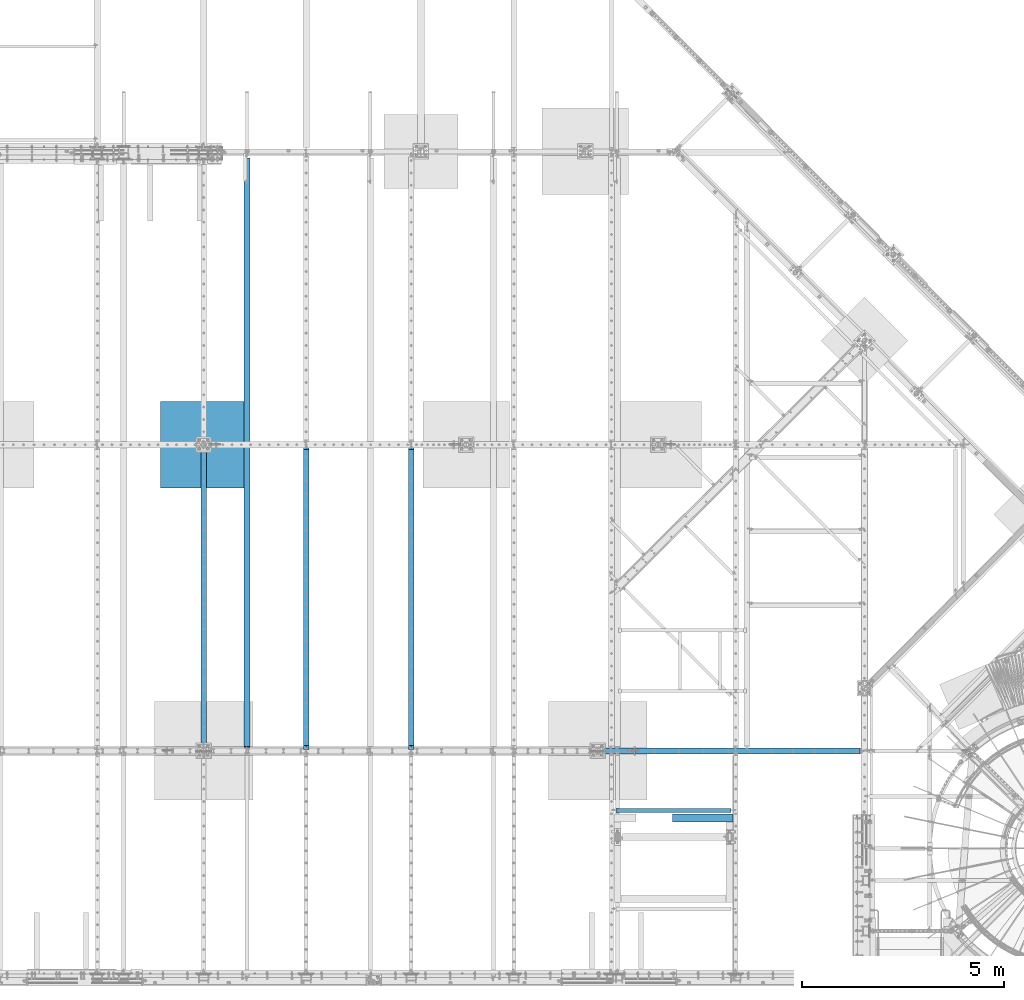
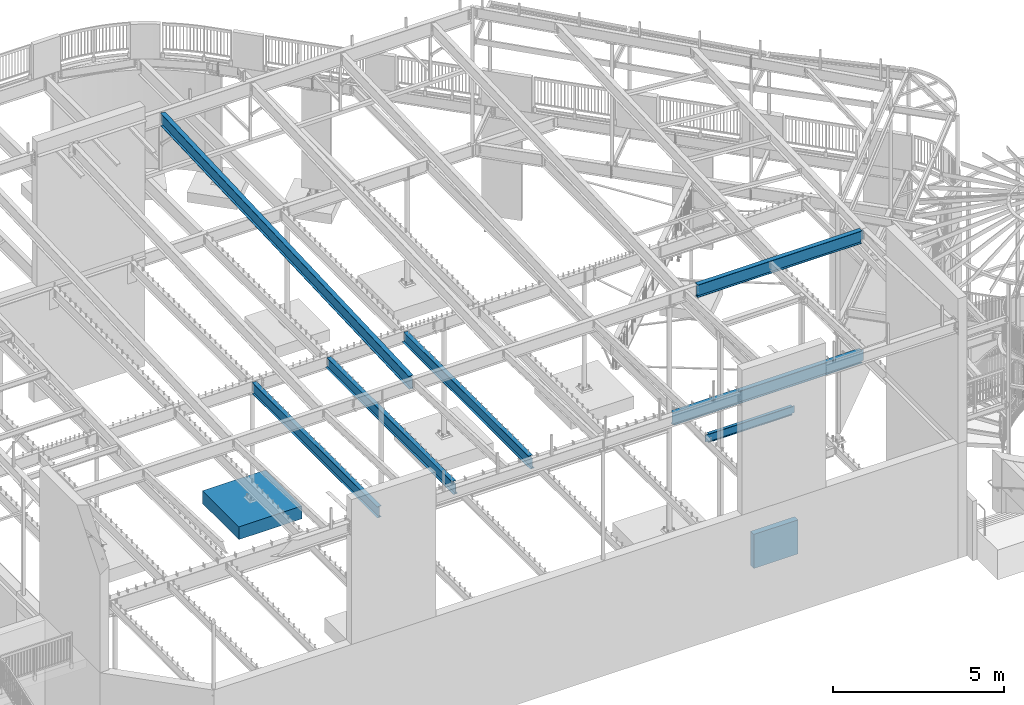
# One storey, part 316 of 975: 9 beams.
"""IFC2X3 building model written with IfcOpenShell, lengths in millimetres."""

from ifc_helpers import new_model, si_unit, frame, origin_with_axes, place, context, subcontext, project, spatial, faceted_brep, material, type_object, element, save


model = new_model("IFC2X3")

# Units and contexts
model_context = context("Model", 3, precision=1e-05, world=origin_with_axes())
body_context = subcontext(model_context, "Body", "Model", "MODEL_VIEW")
ifc_project = project(units=[si_unit("LENGTHUNIT", "METRE", prefix="MILLI"), si_unit("AREAUNIT", "SQUARE_METRE"), si_unit("VOLUMEUNIT", "CUBIC_METRE"), si_unit("MASSUNIT", "GRAM", prefix="KILO"), si_unit("TIMEUNIT", "SECOND"), si_unit("PLANEANGLEUNIT", "RADIAN"), si_unit("SOLIDANGLEUNIT", "STERADIAN"), si_unit("THERMODYNAMICTEMPERATUREUNIT", "DEGREE_CELSIUS"), si_unit("LUMINOUSINTENSITYUNIT", "LUMEN")], contexts=[model_context])

# Site, building, storey
site_placement = place(None, origin_with_axes())
site = spatial("IfcSite", under=ifc_project, at=site_placement, CompositionType="ELEMENT")
building_placement = place(site_placement, origin_with_axes())
building = spatial("IfcBuilding", under=site, at=building_placement, Name="Undefined", CompositionType="ELEMENT")
storey_placement = place(building_placement, origin_with_axes())
storey = spatial("IfcBuildingStorey", under=building, at=storey_placement, Name="Undefined", CompositionType="ELEMENT", Elevation=0.0)

# Beams
ifc_material_1 = material(Name="CONCRETE/5000")
beam_type_1 = type_object("IfcBeamType", PredefinedType="NOTDEFINED")
beam_1_placement = place(storey_placement, frame((25079.3251220703, 4160.83746255972, -609.6), z_axis=(0.0, 0.0, 1.0), x_axis=(1.0, 0.0, 0.0)))
element("IfcBeam", 1, at=beam_1_placement, inside=storey, type_object=beam_type_1, material=ifc_material_1, Name="WALL", context=body_context, shape_type="Brep", body=[
    faceted_brep([(0.0, 96.8375000000001, -609.6), (0.0, 96.8375000000001, 609.6), (1501.77487792969, 96.8374999999996, 609.6), (1501.77487792969, 96.8374999999996, -609.6), (0.0, -96.8375000000001, 609.6), (1501.77487792969, -96.8375000000001, 609.6), (0.0, -96.8375000000001, -609.6), (1501.77487792969, -96.8375000000001, -609.6)], [[[0, 1, 2, 3]], [[1, 4, 5, 2]], [[4, 6, 7, 5]], [[6, 0, 3, 7]], [[5, 7, 3, 2]], [[6, 4, 1, 0]]]),
])
ifc_material_2 = material(Name="STEEL/A992")
beam_type_2 = type_object("IfcBeamType", Name="W18X40", PredefinedType="NOTDEFINED")
beam_2_placement = place(storey_placement, frame((14557.375, 5829.11637334778, 8002.77977754138), z_axis=(0.0, -0.0411491589862163, 0.999153014665285), x_axis=(0.0, 0.999153014665285, 0.0411491589862177)))
element("IfcBeam", 2, at=beam_2_placement, inside=storey, type_object=beam_type_2, material=ifc_material_2, Name="BEAM", ObjectType="W18X40", context=body_context, shape_type="Brep", body=[
    faceted_brep([(14657.5609744888, -76.2000000000007, -214.312499994021), (14657.5609744888, -76.2000000000007, -227.012499992623), (14657.5609744888, 76.2000000000007, -227.012499994023), (14657.5609744888, 76.2000000000007, -214.312499994021), (14657.5609744888, 3.96875, -214.312499994021), (14657.5609744888, -3.96875, -214.312499994021), (14658.5277044114, 3.96865543364765, -209.452420103776), (14658.5277044114, -3.96875, -209.452420103776), (14661.2807183119, 3.96865541555962, -205.332243635633), (14661.2807183119, -3.96875, -205.332243635633), (14665.40089478, 3.9686554016771, -202.579229735162), (14665.40089478, -3.96875, -202.579229735162), (14670.2609742981, 3.9686553941101, -201.612499812572), (14670.2609742981, -3.96875, -201.612499812572), (14765.5109744548, -3.96875, -201.612499812583), (14765.5109744548, 3.96875, -201.612499812583), (109.117370300622, 3.96875, 214.312500000065), (109.117370300622, 76.2000000000007, 214.312500000065), (14676.6109744899, 76.2000000000007, 214.312500006024), (14676.6109744899, 3.96875, 214.312500006024), (71.0173703004075, -3.96875, -207.962499809312), (71.0173703004075, 3.96875, -207.962499809312), (71.0173703004093, 3.96875, -214.312499999988), (71.0173703004093, 76.2000000000007, -214.312499999988), (71.0173703004139, 76.2000000000007, -227.012499999989), (71.0173703004148, -76.2000000000007, -227.012499809476), (71.0173703004093, -76.2000000000007, -214.312499999988), (71.0173703004093, -3.96875, -214.312499999988), (70.0506403778163, -3.96875, -203.102420291266), (70.0506403778163, 3.96875, -203.102420291266), (67.2976264773361, -3.96875, -198.982243823111), (67.2976264773361, 3.96875, -198.982243823111), (63.1774500091806, -3.96875, -196.229229922636), (63.1774500091806, 3.96875, -196.229229922636), (58.3173704911333, -3.96875, -195.262500000049), (58.3173704911333, 3.96875, -195.262500000049), (8.8249636104365, -3.96875, -195.262500000069), (8.8249636104365, 3.96875, -195.262500000069), (24.9083613255289, -3.96875, 195.262500000009), (24.9083613255289, 3.96875, 195.262500000009), (96.4173704913837, -3.96875, 195.262500000037), (96.4173704913837, 3.96875, 195.262500000037), (101.277450009429, -3.96875, 196.229229922624), (101.277450009429, 3.96875, 196.229229922624), (105.397626477584, -3.96875, 198.9822438231), (105.397626477584, 3.96875, 198.9822438231), (108.15064037806, -3.96875, 203.102420291253), (108.15064037806, 3.96875, 203.102420291253), (109.117370300646, -3.96875, 207.962499809298), (109.117370300646, 3.96875, 207.962499809298), (109.117370300628, -76.2000000000007, 227.012500000065), (109.117370300628, 76.2000000000007, 227.012500000065), (109.117370300622, -3.96875, 214.312500000065), (109.117370300622, -76.2000000000007, 214.312500000065), (14676.6109744899, -3.96875, 214.312500006024), (14676.6109744899, -76.2000000000007, 214.312500006024), (14676.6109744899, -76.2000000000007, 227.012500006025), (14676.6109744899, 76.2000000000007, 227.012500006025), (14677.5777044125, -3.96875, 209.452420478925), (14677.5777044125, 3.96826458708529, 209.452420478925), (14680.330718313, -3.96875, 205.332244010762), (14680.330718313, 3.96826481508469, 205.332244010762), (14684.4508947812, -3.96875, 202.579230110274), (14684.4508947812, 3.96826496742869, 202.579230110274), (14689.3109742992, -3.96875, 201.612500187682), (14689.3109742992, 3.96826502092517, 201.612500187682), (14765.5109744548, -3.96875, 201.612500187783), (14765.5109744548, 3.96875, 201.612500187783)], [[[0, 1, 2, 3, 4, 5]], [[5, 4, 6, 7]], [[7, 6, 8, 9]], [[9, 8, 10, 11]], [[11, 10, 12, 13]], [[14, 13, 12, 15]], [[16, 17, 18, 19]], [[20, 21, 22, 23, 24, 25, 26, 27]], [[28, 29, 21, 20]], [[30, 31, 29, 28]], [[32, 33, 31, 30]], [[34, 35, 33, 32]], [[36, 37, 35, 34]], [[38, 39, 37, 36]], [[40, 41, 39, 38]], [[42, 43, 41, 40]], [[44, 45, 43, 42]], [[46, 47, 45, 44]], [[48, 49, 47, 46]], [[50, 51, 17, 16, 49, 48, 52, 53]], [[53, 52, 54, 55]], [[50, 53, 55, 56]], [[51, 50, 56, 57]], [[17, 51, 57, 18]], [[56, 55, 54, 19, 18, 57]], [[58, 59, 19, 54]], [[60, 61, 59, 58]], [[62, 63, 61, 60]], [[64, 65, 63, 62]], [[66, 67, 65, 64]], [[67, 66, 14, 15]], [[10, 8, 6, 4, 22, 21, 29, 31, 33, 35, 37, 39, 41, 43, 45, 47, 49, 16, 19, 59, 61, 63, 65, 67, 15, 12]], [[23, 22, 4, 3]], [[24, 23, 3, 2]], [[25, 24, 2, 1]], [[26, 25, 1, 0]], [[27, 26, 0, 5]], [[66, 64, 62, 60, 58, 54, 52, 48, 46, 44, 42, 40, 38, 36, 34, 32, 30, 28, 20, 27, 5, 7, 9, 11, 13, 14]]]),
])
beam_type_3 = type_object("IfcBeamType", Name="W16X26", PredefinedType="NOTDEFINED")
beam_3_placement = place(storey_placement, frame((18618.2, 5819.775, 3736.975), z_axis=(0.0, 0.0, 1.0), x_axis=(0.0, 1.0, 0.0)))
element("IfcBeam", 3, at=beam_3_placement, inside=storey, type_object=beam_type_3, material=ifc_material_2, Name="BEAM", ObjectType="W16X26", context=body_context, shape_type="Brep", body=[
    faceted_brep([(126.206250190731, -3.17499999999927, 174.625), (126.206250190731, 3.17499999999927, 174.625), (30.9562499999956, 3.17499999999927, 174.625), (30.9562499999956, -3.17499999999927, 174.625), (131.066329708777, -3.17499999999927, 175.591729922588), (131.066329708777, 3.17499999999927, 175.591729922588), (135.18650617693, -3.17499999999927, 178.344743823066), (135.18650617693, 3.17499999999927, 178.344743823066), (137.939520077409, -3.17499999999927, 182.46492029122), (137.939520077409, 3.17499999999927, 182.46492029122), (138.906249999996, -3.17499999999927, 187.324999809266), (138.906249999996, 3.17499999999927, 187.324999809266), (138.906249999996, -69.8499999999985, 200.025), (138.906249999996, 69.8499999999985, 200.025), (138.906249999996, 69.8499999999985, 190.5), (138.906249999996, 3.17499999999927, 190.5), (138.906249999996, -3.17499999999927, 190.5), (138.906249999996, -69.8499999999985, 190.5), (30.9562499999956, -3.17499999999927, -190.5), (30.9562499999956, -69.8499999999985, -190.5), (7543.00625, -69.8499999999985, -190.5), (7543.00625, -3.17499999999927, -190.5), (30.9562499999956, -69.8499999999985, -200.025), (7543.00625, -69.8499999999985, -200.025), (30.9562499999956, 69.8499999999985, -200.025), (7543.00625, 69.8499999999985, -200.025), (30.9562499999956, 69.8499999999985, -190.5), (7543.00625, 69.8499999999985, -190.5), (30.9562499999956, 3.17499999999927, -190.5), (7543.00625, 3.17499999999927, -190.5), (7543.00625, 3.17499999999927, 174.625), (7543.00625, -3.17499999999927, 174.625), (7466.80624980926, 3.17499999999927, 174.625), (7466.80624980926, -3.17499999999927, 174.625), (7461.94617029122, 3.17499999999927, 175.591729922588), (7461.94617029122, -3.17499999999927, 175.591729922588), (7457.82599382307, 3.17499999999927, 178.344743823066), (7457.82599382307, -3.17499999999927, 178.344743823066), (7455.07297992259, 3.17499999999927, 182.46492029122), (7455.07297992259, -3.17499999999927, 182.46492029122), (7454.10625, 3.17499999999927, 187.324999809266), (7454.10625, -3.17499999999927, 187.324999809266), (7454.10625, -69.8499999999985, 200.025), (7454.10625, -69.8499999999985, 190.5), (7454.10625, -3.17499999999927, 190.5), (7454.10625, 3.17499999999927, 190.5), (7454.10625, 69.8499999999985, 190.5), (7454.10625, 69.8499999999985, 200.025)], [[[0, 1, 2, 3]], [[4, 5, 1, 0]], [[6, 7, 5, 4]], [[8, 9, 7, 6]], [[10, 11, 9, 8]], [[12, 13, 14, 15, 11, 10, 16, 17]], [[18, 19, 20, 21]], [[19, 22, 23, 20]], [[22, 24, 25, 23]], [[24, 26, 27, 25]], [[26, 28, 29, 27]], [[21, 20, 23, 25, 27, 29, 30, 31]], [[31, 30, 32, 33]], [[33, 32, 34, 35]], [[35, 34, 36, 37]], [[37, 36, 38, 39]], [[39, 38, 40, 41]], [[42, 43, 44, 41, 40, 45, 46, 47]], [[43, 42, 12, 17]], [[44, 43, 17, 16]], [[8, 6, 4, 0, 3, 18, 21, 31, 33, 35, 37, 39, 41, 44, 16, 10]], [[28, 26, 24, 22, 19, 18, 3, 2]], [[45, 40, 38, 36, 34, 32, 30, 29, 28, 2, 1, 5, 7, 9, 11, 15]], [[46, 45, 15, 14]], [[47, 46, 14, 13]], [[42, 47, 13, 12]]]),
])
beam_4_placement = place(storey_placement, frame((16021.05, 5819.775, 3736.975), z_axis=(0.0, 0.0, 1.0), x_axis=(0.0, 1.0, 0.0)))
element("IfcBeam", 4, at=beam_4_placement, inside=storey, type_object=beam_type_3, material=ifc_material_2, Name="BEAM", ObjectType="W16X26", context=body_context, shape_type="Brep", body=[
    faceted_brep([(126.206250190731, -3.17499999999927, 174.625), (126.206250190731, 3.17499999999927, 174.625), (30.9562499999956, 3.17499999999927, 174.625), (30.9562499999956, -3.17499999999927, 174.625), (131.066329708777, -3.17499999999927, 175.591729922588), (131.066329708777, 3.17499999999927, 175.591729922588), (135.18650617693, -3.17499999999927, 178.344743823066), (135.18650617693, 3.17499999999927, 178.344743823066), (137.939520077409, -3.17499999999927, 182.46492029122), (137.939520077409, 3.17499999999927, 182.46492029122), (138.906249999996, -3.17499999999927, 187.324999809266), (138.906249999996, 3.17499999999927, 187.324999809266), (138.906249999996, -69.8499999999985, 200.025), (138.906249999996, 69.8499999999985, 200.025), (138.906249999996, 69.8499999999985, 190.5), (138.906249999996, 3.17499999999927, 190.5), (138.906249999996, -3.17499999999927, 190.5), (138.906249999996, -69.8499999999985, 190.5), (30.9562499999956, -3.17499999999927, -190.5), (30.9562499999956, -69.8499999999985, -190.5), (7543.00625, -69.8499999999985, -190.5), (7543.00625, -3.17499999999927, -190.5), (30.9562499999956, -69.8499999999985, -200.025), (7543.00625, -69.8499999999985, -200.025), (30.9562499999956, 69.8499999999985, -200.025), (7543.00625, 69.8499999999985, -200.025), (30.9562499999956, 69.8499999999985, -190.5), (7543.00625, 69.8499999999985, -190.5), (30.9562499999956, 3.17499999999927, -190.5), (7543.00625, 3.17499999999927, -190.5), (7543.00625, 3.17499999999927, 174.625), (7543.00625, -3.17499999999927, 174.625), (7466.80624980926, 3.17499999999927, 174.625), (7466.80624980926, -3.17499999999927, 174.625), (7461.94617029122, 3.17499999999927, 175.591729922588), (7461.94617029122, -3.17499999999927, 175.591729922588), (7457.82599382307, 3.17499999999927, 178.344743823066), (7457.82599382307, -3.17499999999927, 178.344743823066), (7455.07297992259, 3.17499999999927, 182.46492029122), (7455.07297992259, -3.17499999999927, 182.46492029122), (7454.10625, 3.17499999999927, 187.324999809266), (7454.10625, -3.17499999999927, 187.324999809266), (7454.10625, -69.8499999999985, 200.025), (7454.10625, -69.8499999999985, 190.5), (7454.10625, -3.17499999999927, 190.5), (7454.10625, 3.17499999999927, 190.5), (7454.10625, 69.8499999999985, 190.5), (7454.10625, 69.8499999999985, 200.025)], [[[0, 1, 2, 3]], [[4, 5, 1, 0]], [[6, 7, 5, 4]], [[8, 9, 7, 6]], [[10, 11, 9, 8]], [[12, 13, 14, 15, 11, 10, 16, 17]], [[18, 19, 20, 21]], [[19, 22, 23, 20]], [[22, 24, 25, 23]], [[24, 26, 27, 25]], [[26, 28, 29, 27]], [[21, 20, 23, 25, 27, 29, 30, 31]], [[31, 30, 32, 33]], [[33, 32, 34, 35]], [[35, 34, 36, 37]], [[37, 36, 38, 39]], [[39, 38, 40, 41]], [[42, 43, 44, 41, 40, 45, 46, 47]], [[43, 42, 12, 17]], [[44, 43, 17, 16]], [[8, 6, 4, 0, 3, 18, 21, 31, 33, 35, 37, 39, 41, 44, 16, 10]], [[28, 26, 24, 22, 19, 18, 3, 2]], [[45, 40, 38, 36, 34, 32, 30, 29, 28, 2, 1, 5, 7, 9, 11, 15]], [[46, 45, 15, 14]], [[47, 46, 14, 13]], [[42, 47, 13, 12]]]),
])
beam_5_placement = place(storey_placement, frame((13487.4, 5819.775, 3736.975), z_axis=(0.0, 0.0, 1.0), x_axis=(0.0, 1.0, 0.0)))
element("IfcBeam", 5, at=beam_5_placement, inside=storey, type_object=beam_type_3, material=ifc_material_2, Name="BEAM", ObjectType="W16X26", context=body_context, shape_type="Brep", body=[
    faceted_brep([(109.600999999999, -3.17499999999927, -190.5), (109.600999999999, -69.8500000000004, -190.5), (7543.00625, -69.8499999999985, -190.5), (7543.00625, -3.17499999999927, -190.5), (109.600999999999, -69.8500000000004, -200.025), (7543.00625, -69.8499999999985, -200.025), (7447.75625, 69.8500000000004, -190.5), (109.600999999999, 69.8500000000004, -190.5), (109.600999999999, 3.17499999999927, -190.5), (7543.00625, 3.17499999999927, -190.5), (7543.00625, 3.47549991607775, -190.5), (7447.75625, 3.47549991607775, -190.5), (7543.00625, 3.47549991607775, -200.025), (7543.00625, 3.17499999999927, 174.625), (7543.00625, -3.17499999999927, 174.625), (7447.75625, 3.47549991607775, -200.025), (109.600999999999, 69.8500000000004, -200.025), (7447.75625, 69.8500000000004, -200.025), (109.600999999999, -3.17499999999927, 190.5), (109.600999999999, -69.8500000000004, 190.5), (109.600999999999, -69.8500000000004, 200.025), (109.600999999999, 69.8500000000004, 200.025), (109.600999999999, 69.8500000000004, 190.5), (109.600999999999, 3.17499999999927, 190.5), (7454.10625, 69.8499999999985, 190.5), (7454.10625, 3.17499999999927, 190.5), (7454.10625, 3.17499999999927, 187.324999809266), (7455.07297992259, 3.17499999999927, 182.46492029122), (7457.82599382307, 3.17499999999927, 178.344743823066), (7461.94617029122, 3.17499999999927, 175.591729922588), (7466.80624980926, 3.17499999999927, 174.625), (7455.07297992259, -3.17499999999927, 182.46492029122), (7454.10625, -3.17499999999927, 187.324999809266), (7457.82599382307, -3.17499999999927, 178.344743823066), (7461.94617029122, -3.17499999999927, 175.591729922588), (7466.80624980926, -3.17499999999927, 174.625), (7454.10625, -3.17499999999927, 190.5), (7454.10625, -69.8499999999985, 190.5), (7454.10625, -69.8499999999985, 200.025), (7454.10625, 69.8499999999985, 200.025)], [[[0, 1, 2, 3]], [[1, 4, 5, 2]], [[6, 7, 8, 9, 10, 11]], [[3, 2, 5, 12, 10, 9, 13, 14]], [[10, 12, 15, 11]], [[5, 4, 16, 17, 15, 12]], [[11, 15, 17, 6]], [[16, 7, 6, 17]], [[4, 1, 0, 18, 19, 20, 21, 22, 23, 8, 7, 16]], [[23, 22, 24, 25]], [[9, 8, 23, 25, 26, 27, 28, 29, 30, 13]], [[31, 27, 26, 32]], [[33, 28, 27, 31]], [[34, 29, 28, 33]], [[35, 30, 29, 34]], [[14, 13, 30, 35]], [[34, 33, 31, 32, 36, 18, 0, 3, 14, 35]], [[19, 18, 36, 37]], [[20, 19, 37, 38]], [[21, 20, 38, 39]], [[22, 21, 39, 24]], [[38, 37, 36, 32, 26, 25, 24, 39]]]),
])
beam_type_4 = type_object("IfcBeamType", Name="W18X35", PredefinedType="NOTDEFINED")
beam_6_placement = place(storey_placement, frame((24147.4625, 5819.775, 8004.175), z_axis=(0.0, 0.0, 1.0), x_axis=(1.0, 0.0, 0.0)))
element("IfcBeam", 6, at=beam_6_placement, inside=storey, type_object=beam_type_4, material=ifc_material_2, Name="BEAM", ObjectType="W18X35", context=body_context, shape_type="Brep", body=[
    faceted_brep([(5566.56874999999, -3.96875, -214.3125), (5566.56874999999, -76.1999999999998, -214.3125), (5566.56874999999, -76.1999999999998, -225.425), (5566.56874999999, 76.1999999999998, -225.425), (5566.56874999999, 76.1999999999998, -214.3125), (5566.56874999999, 3.96875, -214.3125), (5566.56874999999, 3.96875, -155.574999809995), (5566.56874999999, -3.96875, -155.574999809995), (5567.53547992258, 3.96875, -150.71492029195), (5567.53547992258, -3.96875, -150.71492029195), (5570.28849382306, 3.96875, -146.594743823796), (5570.28849382306, -3.96875, -146.594743823796), (5574.40867029121, 3.96875, -143.841729923318), (5574.40867029121, -3.96875, -143.841729923318), (5579.26874980926, 3.96875, -142.87500000073), (5579.26874980926, -3.96875, -142.87500000073), (5655.46875, -3.96875, -142.87500000073), (5655.46875, 3.96875, -142.87500000073), (3.17496870515606, 3.96875, 214.312499999999), (3.17496870515606, 76.1999999999998, 214.312499999999), (5566.56874999999, 76.1999999999998, 214.312499999999), (5566.56874999999, 3.96875, 214.312499999999), (14.6840158801024, -3.96875, -213.91549949646), (14.6840158801024, 3.96875, -213.91549949646), (14.2870309973041, 3.96875, -214.3125), (14.2870309973041, 76.1999999999998, -214.3125), (3.17496823977854, 76.1999999999998, -225.425), (3.17496823977854, -76.1999999999998, -225.425), (14.2870309973041, -76.1999999999998, -214.3125), (14.2870309973041, -3.96875, -214.3125), (34.1309994812, -3.96875, -213.91549949646), (34.1309994812, 3.96875, -213.91549949646), (52.6182670230592, -3.96875, -203.575605287907), (52.6182670230592, 3.96875, -203.575605287907), (56.7309521802672, -3.96875, -198.997422721185), (56.7309521802672, 3.96875, -198.997422721185), (57.1858105045285, -3.96875, -192.860074863893), (57.1858105045285, 3.96875, -192.860074863893), (53.7929587527833, -3.96875, -187.72563314086), (53.7929587527833, 3.96875, -187.72563314086), (47.9687625480874, -3.96875, -185.7375), (47.9687625480874, 3.96875, -185.7375), (6.34999999999854, -3.96875, -185.7375), (6.34999999999854, 3.96875, -185.7375), (6.34999999999854, -3.96875, 185.737499999999), (6.34999999999854, 3.96875, 185.737499999999), (36.0627638298283, -3.96875, 185.737499999999), (36.0627638298283, 3.96875, 185.737499999999), (41.8869600345242, -3.96875, 187.725633140859), (41.8869600345242, 3.96875, 187.725633140859), (45.2798117862694, -3.96875, 192.860074863892), (45.2798117862694, 3.96875, 192.860074863892), (44.8249534620081, -3.96875, 198.997422721183), (44.8249534620081, 3.96875, 198.997422721183), (40.7122683048001, -3.96875, 203.575605287907), (40.7122683048001, 3.96875, 203.575605287907), (22.2250007629409, -3.96875, 213.915499496458), (22.2250007629409, 3.96875, 213.915499496458), (2.77798382235414, -3.96875, 213.915499496458), (2.77798382235414, 3.96875, 213.915499496458), (14.287031462678, -76.1999999999998, 225.425), (14.287031462678, 76.1999999999998, 225.425), (3.17496870515606, -3.96875, 214.312499999999), (3.17496870515606, -76.1999999999998, 214.312499999999), (5566.56874999999, -3.96875, 214.312499999999), (5566.56874999999, -76.1999999999998, 214.312499999999), (5566.56874999999, -76.1999999999998, 225.425), (5566.56874999999, 76.1999999999998, 225.425), (5566.56874999999, -3.96875, 212.724999808554), (5566.56874999999, 3.96875, 212.724999808554), (5567.53547992258, -3.96875, 207.864920290508), (5567.53547992258, 3.96875, 207.864920290508), (5570.28849382306, -3.96875, 203.744743822354), (5570.28849382306, 3.96875, 203.744743822354), (5574.40867029121, -3.96875, 200.991729921877), (5574.40867029121, 3.96875, 200.991729921877), (5579.26874980926, -3.96875, 200.024999999289), (5579.26874980926, 3.96875, 200.024999999289), (5655.46875, -3.96875, 200.024999999289), (5655.46875, 3.96875, 200.024999999289)], [[[0, 1, 2, 3, 4, 5, 6, 7]], [[7, 6, 8, 9]], [[9, 8, 10, 11]], [[11, 10, 12, 13]], [[13, 12, 14, 15]], [[16, 15, 14, 17]], [[18, 19, 20, 21]], [[22, 23, 24, 25, 26, 27, 28, 29]], [[30, 31, 23, 22]], [[32, 33, 31, 30]], [[34, 35, 33, 32]], [[36, 37, 35, 34]], [[38, 39, 37, 36]], [[40, 41, 39, 38]], [[41, 40, 42, 43]], [[44, 45, 43, 42]], [[46, 47, 45, 44]], [[48, 49, 47, 46]], [[50, 51, 49, 48]], [[52, 53, 51, 50]], [[54, 55, 53, 52]], [[56, 57, 55, 54]], [[57, 56, 58, 59]], [[60, 61, 19, 18, 59, 58, 62, 63]], [[63, 62, 64, 65]], [[60, 63, 65, 66]], [[61, 60, 66, 67]], [[19, 61, 67, 20]], [[66, 65, 64, 68, 69, 21, 20, 67]], [[70, 71, 69, 68]], [[72, 73, 71, 70]], [[74, 75, 73, 72]], [[76, 77, 75, 74]], [[78, 79, 77, 76]], [[79, 78, 16, 17]], [[12, 10, 8, 6, 5, 24, 23, 31, 33, 35, 37, 39, 41, 43, 45, 47, 49, 51, 53, 55, 57, 59, 18, 21, 69, 71, 73, 75, 77, 79, 17, 14]], [[25, 24, 5, 4]], [[26, 25, 4, 3]], [[27, 26, 3, 2]], [[28, 27, 2, 1]], [[29, 28, 1, 0]], [[78, 76, 74, 72, 70, 68, 64, 62, 58, 56, 54, 52, 50, 48, 46, 44, 42, 40, 38, 36, 34, 32, 30, 22, 29, 0, 7, 9, 11, 13, 15, 16]]]),
])
beam_7_placement = place(storey_placement, frame((23233.0625, 5819.775, 3711.575), z_axis=(0.0, 0.0, 1.0), x_axis=(1.0, 0.0, 0.0)))
element("IfcBeam", 7, at=beam_7_placement, inside=storey, type_object=beam_type_4, material=ifc_material_2, Name="BEAM", ObjectType="W18X35", context=body_context, shape_type="Brep", body=[
    faceted_brep([(6500.01875, -3.96875, -214.3125), (6500.01875, -76.1999999999998, -214.3125), (6500.01875, -76.1999999999998, -225.425), (6500.01875, 76.1999999999998, -225.425), (6500.01875, 76.1999999999998, -214.3125), (6500.01875, 3.96875, -214.3125), (6500.01875, 3.96875, -212.724999809265), (6500.01875, -3.96875, -212.724999809265), (6500.98547992259, 3.96875, -207.864920291219), (6500.98547992259, -3.96875, -207.864920291219), (6503.73849382307, 3.96875, -203.744743823066), (6503.73849382307, -3.96875, -203.744743823066), (6507.85867029122, 3.96875, -200.991729922588), (6507.85867029122, -3.96875, -200.991729922588), (6512.71874980927, 3.96875, -200.025), (6512.71874980927, -3.96875, -200.025), (6569.86875, -3.96875, -200.025), (6569.86875, 3.96875, -200.025), (96.9010000000017, 3.96875, 214.3125), (96.9010000000017, 76.1999999999998, 214.3125), (6474.61875, 76.1999999999998, 214.3125), (6480.96875, 76.1999999999998, 214.3125), (6480.96875, 3.96875, 214.3125), (127.919505810281, -76.1999999999998, -214.3125), (127.919505810281, -5.85624999999982, -214.3125), (127.919505810281, -5.85624999999982, -225.425), (127.919505810281, -76.1999999999998, -225.425), (96.9010000000017, -5.85624999999982, -214.3125), (96.9010000000017, -5.85624999999982, -225.425), (96.9010000000017, -3.96875, -214.3125), (96.9010000000017, -3.96875, 214.3125), (96.9010000000017, -76.1999999999998, 214.3125), (96.9010000000017, -76.1999999999998, 225.425), (96.9010000000017, 76.1999999999998, 225.425), (96.9010000000017, 3.96875, -214.3125), (96.9010000000017, 76.1999999999998, -214.3125), (96.9010000000017, 76.1999999999998, -225.425), (6480.96875, -3.96875, 214.3125), (6480.96875, -76.1999999999998, 214.3125), (6480.96875, -76.1999999999998, 225.425), (6480.96875, 76.1999999999998, 225.425), (6480.96875, -3.96875, 212.724999809266), (6480.96875, 3.96875, 212.724999809266), (6481.93547992259, -3.96875, 207.86492029122), (6481.93547992259, 3.96875, 207.86492029122), (6484.68849382307, -3.96875, 203.744743823067), (6484.68849382307, 3.96875, 203.744743823067), (6488.80867029122, -3.96875, 200.991729922589), (6488.80867029122, 3.96875, 200.991729922589), (6493.66874980927, -3.96875, 200.025000000001), (6493.66874980927, 3.96875, 200.025000000001), (6569.86875, -3.96875, 200.025000000001), (6569.86875, 3.96875, 200.025000000001)], [[[0, 1, 2, 3, 4, 5, 6, 7]], [[7, 6, 8, 9]], [[9, 8, 10, 11]], [[11, 10, 12, 13]], [[13, 12, 14, 15]], [[16, 15, 14, 17]], [[18, 19, 20, 21, 22]], [[23, 24, 25, 26]], [[27, 28, 25, 24]], [[29, 30, 31, 32, 33, 19, 18, 34, 35, 36, 28, 27]], [[31, 30, 37, 38]], [[32, 31, 38, 39]], [[33, 32, 39, 40]], [[20, 19, 33, 40, 21]], [[39, 38, 37, 41, 42, 22, 21, 40]], [[43, 44, 42, 41]], [[45, 46, 44, 43]], [[47, 48, 46, 45]], [[49, 50, 48, 47]], [[51, 52, 50, 49]], [[52, 51, 16, 17]], [[12, 10, 8, 6, 5, 34, 18, 22, 42, 44, 46, 48, 50, 52, 17, 14]], [[35, 34, 5, 4]], [[36, 35, 4, 3]], [[26, 25, 28, 36, 3, 2]], [[23, 26, 2, 1]], [[29, 27, 24, 23, 1, 0]], [[51, 49, 47, 45, 43, 41, 37, 30, 29, 0, 7, 9, 11, 13, 15, 16]]]),
])
beam_type_5 = type_object("IfcBeamType", Name="W12X19", PredefinedType="NOTDEFINED")
beam_8_placement = place(storey_placement, frame((23571.2, 4346.26465672034, 3783.0125), z_axis=(0.0, 0.0, 1.0), x_axis=(1.0, 0.0, 0.0)))
element("IfcBeam", 8, at=beam_8_placement, inside=storey, type_object=beam_type_5, material=ifc_material_2, Name="BEAM", ObjectType="W12X19", context=body_context, shape_type="Brep", body=[
    faceted_brep([(2955.925, -3.17499999999995, -144.4625), (2955.925, -50.8, -144.4625), (2955.925, -50.8, -153.98749999433), (2955.925, 50.8, -153.9875), (2955.925, 50.8000000000002, -144.4625), (2955.925, 3.17499999999995, -144.4625), (2955.925, 3.17499999999995, -141.287499809265), (2955.925, -3.17499999999995, -141.287499809265), (2956.89172992258, 3.17499999999995, -136.42742029122), (2956.89172992258, -3.17499999999995, -136.42742029122), (2959.64474382306, 3.17499999999995, -132.307243823066), (2959.64474382306, -3.17499999999995, -132.307243823066), (2963.76492029121, 3.17499999999995, -129.554229922588), (2963.76492029121, -3.17499999999995, -129.554229922588), (2968.62499980926, 3.17499999999995, -128.5875), (2968.62499980926, -3.17499999999995, -128.5875), (3044.825, -3.17499999999995, -128.5875), (3044.825, 3.17499999999995, -128.5875), (117.475000000002, 3.17499999999995, 144.4625), (117.475000000002, 50.8, 144.4625), (2955.925, 50.8, 144.4625), (2955.925, 3.17499999999995, 144.4625), (117.475000000002, -3.17499999999995, -141.287499809264), (117.475000000002, 3.17499999999995, -141.287499809264), (117.475000000002, 3.17499999999995, -144.4625), (117.475000000002, 50.8000000000002, -144.4625), (117.475000000002, 50.8, -153.9875), (117.475000000002, -50.8, -153.987499813315), (117.475000000002, -50.8, -144.4625), (117.475000000002, -3.17499999999995, -144.4625), (116.508270077415, -3.17499999999995, -136.427420291219), (116.508270077415, 3.17499999999995, -136.427420291219), (113.755256176937, -3.17499999999995, -132.307243823065), (113.755256176937, 3.17499999999995, -132.307243823065), (109.635079708783, -3.17499999999995, -129.554229922587), (109.635079708783, 3.17499999999995, -129.554229922587), (104.775000190737, -3.17499999999995, -128.587499999999), (104.775000190737, 3.17499999999995, -128.587499999999), (28.5750000000007, -3.17499999999995, -128.587499999999), (28.5750000000007, 3.17499999999995, -128.587499999999), (28.5750000000007, -3.17499999999995, 128.587500000001), (28.5750000000007, 3.17499999999995, 128.587500000001), (104.775000190737, -3.17499999999995, 128.587500000001), (104.775000190737, 3.17499999999995, 128.587500000001), (109.635079708783, -3.17499999999995, 129.554229922589), (109.635079708783, 3.17499999999995, 129.554229922589), (113.755256176937, -3.17499999999995, 132.307243823067), (113.755256176937, 3.17499999999995, 132.307243823067), (116.508270077415, -3.17499999999995, 136.427420291221), (116.508270077415, 3.17499999999995, 136.427420291221), (117.475000000002, -3.17499999999995, 141.287499809266), (117.475000000002, 3.17499999999995, 141.287499809266), (117.475000000002, -50.8, 153.987499813315), (117.475000000002, 50.8, 153.9875), (117.475000000002, -3.17499999999995, 144.4625), (117.475000000002, -50.8, 144.4625), (2955.925, -3.17499999999995, 144.4625), (2955.925, -50.8, 144.4625), (2955.925, -50.8, 153.98749999433), (2955.925, 50.8, 153.9875), (2955.925, -3.17499999999995, 141.287499809265), (2955.925, 3.17499999999995, 141.287499809265), (2956.89172992258, -3.17499999999995, 136.42742029122), (2956.89172992258, 3.17499999999995, 136.42742029122), (2959.64474382306, -3.17499999999995, 132.307243823066), (2959.64474382306, 3.17499999999995, 132.307243823066), (2963.76492029121, -3.17499999999995, 129.554229922588), (2963.76492029121, 3.17499999999995, 129.554229922588), (2968.62499980926, -3.17499999999995, 128.5875), (2968.62499980926, 3.17499999999995, 128.5875), (3044.825, -3.17499999999995, 128.5875), (3044.825, 3.17499999999995, 128.5875)], [[[0, 1, 2, 3, 4, 5, 6, 7]], [[7, 6, 8, 9]], [[9, 8, 10, 11]], [[11, 10, 12, 13]], [[13, 12, 14, 15]], [[16, 15, 14, 17]], [[18, 19, 20, 21]], [[22, 23, 24, 25, 26, 27, 28, 29]], [[30, 31, 23, 22]], [[32, 33, 31, 30]], [[34, 35, 33, 32]], [[36, 37, 35, 34]], [[38, 39, 37, 36]], [[40, 41, 39, 38]], [[42, 43, 41, 40]], [[44, 45, 43, 42]], [[46, 47, 45, 44]], [[48, 49, 47, 46]], [[50, 51, 49, 48]], [[52, 53, 19, 18, 51, 50, 54, 55]], [[55, 54, 56, 57]], [[52, 55, 57, 58]], [[53, 52, 58, 59]], [[19, 53, 59, 20]], [[58, 57, 56, 60, 61, 21, 20, 59]], [[62, 63, 61, 60]], [[64, 65, 63, 62]], [[66, 67, 65, 64]], [[68, 69, 67, 66]], [[70, 71, 69, 68]], [[71, 70, 16, 17]], [[12, 10, 8, 6, 5, 24, 23, 31, 33, 35, 37, 39, 41, 43, 45, 47, 49, 51, 18, 21, 61, 63, 65, 67, 69, 71, 17, 14]], [[25, 24, 5, 4]], [[26, 25, 4, 3]], [[27, 26, 3, 2]], [[28, 27, 2, 1]], [[29, 28, 1, 0]], [[70, 68, 66, 64, 62, 60, 56, 54, 50, 48, 46, 44, 42, 40, 38, 36, 34, 32, 30, 22, 29, 0, 7, 9, 11, 13, 15, 16]]]),
])
beam_type_6 = type_object("IfcBeamType", PredefinedType="NOTDEFINED")
beam_9_placement = place(storey_placement, frame((12420.5999938965, 13392.15, -533.4), z_axis=(0.0, 0.0, 1.0), x_axis=(1.0, 0.0, 0.0)))
element("IfcBeam", 9, at=beam_9_placement, inside=storey, type_object=beam_type_6, material=ifc_material_1, Name="FOOTING", context=body_context, shape_type="Brep", body=[
    faceted_brep([(0.0, 1066.8, -228.6), (0.0, 1066.8, 228.6), (2133.6, 1066.8, 228.6), (2133.6, 1066.8, -228.6), (0.0, -1066.8, 228.6), (2133.6, -1066.8, 228.6), (0.0, -1066.8, -228.6), (2133.6, -1066.8, -228.6)], [[[0, 1, 2, 3]], [[1, 4, 5, 2]], [[4, 6, 7, 5]], [[6, 0, 3, 7]], [[5, 7, 3, 2]], [[6, 4, 1, 0]]]),
])

save(model, "model.ifc")
